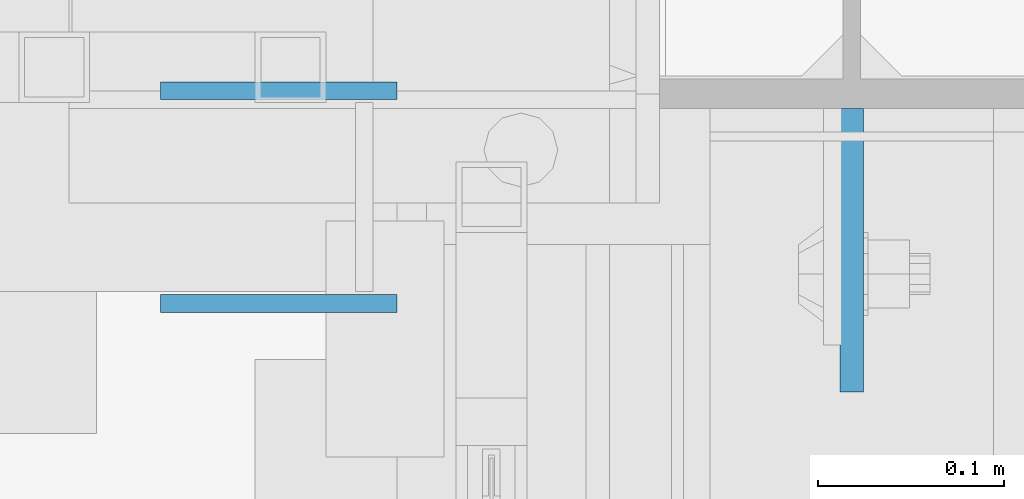
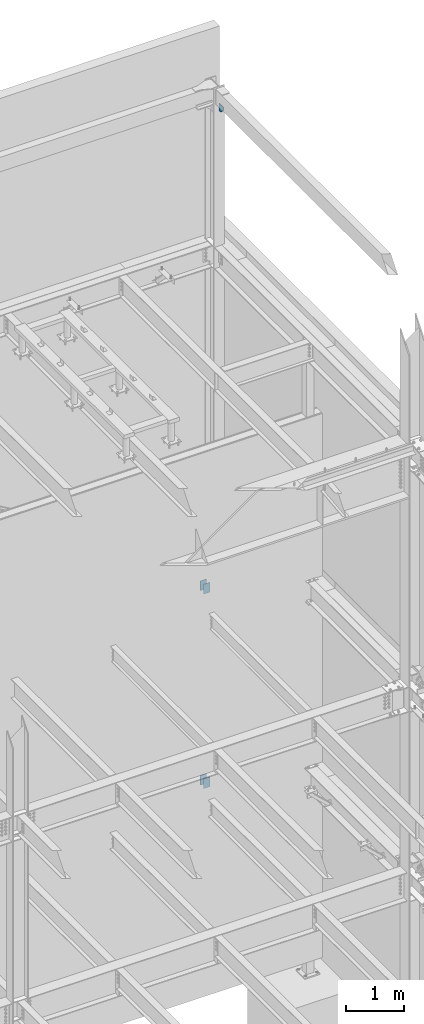
# One storey, part 1115 of 1179: 5 plates, 3 elements without a shape of their own.
"""IFC2X3 building model written with IfcOpenShell, lengths in millimetres."""

from ifc_helpers import new_model, si_unit, frame, origin_with_axes, place, context, subcontext, project, spatial, faceted_brep, material, type_object, element, aggregate, save


model = new_model("IFC2X3")

# Units and contexts
model_context = context("Model", 3, precision=1e-05, world=origin_with_axes())
body_context = subcontext(model_context, "Body", "Model", "MODEL_VIEW")
ifc_project = project(units=[si_unit("LENGTHUNIT", "METRE", prefix="MILLI"), si_unit("AREAUNIT", "SQUARE_METRE"), si_unit("VOLUMEUNIT", "CUBIC_METRE"), si_unit("MASSUNIT", "GRAM", prefix="KILO"), si_unit("TIMEUNIT", "SECOND"), si_unit("PLANEANGLEUNIT", "RADIAN"), si_unit("SOLIDANGLEUNIT", "STERADIAN"), si_unit("THERMODYNAMICTEMPERATUREUNIT", "DEGREE_CELSIUS"), si_unit("LUMINOUSINTENSITYUNIT", "LUMEN")], contexts=[model_context])

# Site, building, storey
site_placement = place(None, origin_with_axes())
site = spatial("IfcSite", under=ifc_project, at=site_placement, CompositionType="ELEMENT")
building_placement = place(site_placement, origin_with_axes())
building = spatial("IfcBuilding", under=site, at=building_placement, Name="Undefined", CompositionType="ELEMENT")
storey_placement = place(building_placement, origin_with_axes())
storey = spatial("IfcBuildingStorey", under=building, at=storey_placement, Name="Undefined", CompositionType="ELEMENT", Elevation=0.0)

# Assembly, plates
assembly_1_placement = place(storey_placement, origin_with_axes())
assembly_1 = element("IfcElementAssembly", 1, at=assembly_1_placement, inside=storey, Name="BEAM", AssemblyPlace="NOTDEFINED", PredefinedType="RIGID_FRAME")
ifc_material = material(Name="STEEL/A36")
plate_type_1 = type_object("IfcPlateType", PredefinedType="NOTDEFINED")
plate_1_placement = place(assembly_1_placement, frame((24063.325, 41052.75, 6191.25000001248), z_axis=(-1.0, 0.0, 0.0), x_axis=(0.0, 0.0, -1.0)))
plate_1 = element("IfcPlate", 2, at=plate_1_placement, type_object=plate_type_1, material=ifc_material, Name="PLATE", context=body_context, shape_type="Brep", body=[
    faceted_brep([(0.0, -4.76249999999709, 0.0), (0.0, -4.76249999999709, 127.0), (0.0, 4.76249999999709, 127.0), (0.0, 4.76249999999709, 0.0), (203.2, -4.76249999999709, 127.0), (203.2, 4.76249999999709, 127.0), (203.2, -4.76249999999709, 0.0), (203.2, 4.76249999999709, 0.0)], [[[0, 1, 2, 3]], [[1, 4, 5, 2]], [[4, 6, 7, 5]], [[6, 0, 3, 7]], [[5, 7, 3, 2]], [[6, 4, 1, 0]]]),
])
plate_2_placement = place(assembly_1_placement, frame((24063.325, 40938.45, 6191.25000001248), z_axis=(-1.0, 0.0, 0.0), x_axis=(0.0, 0.0, -1.0)))
plate_2 = element("IfcPlate", 3, at=plate_2_placement, type_object=plate_type_1, material=ifc_material, Name="PLATE", context=body_context, shape_type="Brep", body=[
    faceted_brep([(0.0, -4.76249999999709, 0.0), (0.0, -4.76249999999709, 127.0), (0.0, 4.76249999999709, 127.0), (0.0, 4.76249999999709, 0.0), (203.2, -4.76249999999709, 127.0), (203.2, 4.76249999999709, 127.0), (203.2, -4.76249999999709, 0.0), (203.2, 4.76249999999709, 0.0)], [[[0, 1, 2, 3]], [[1, 4, 5, 2]], [[4, 6, 7, 5]], [[6, 0, 3, 7]], [[5, 7, 3, 2]], [[6, 4, 1, 0]]]),
])
aggregate(assembly_1, [plate_1, plate_2])

assembly_2_placement = place(storey_placement, origin_with_axes())
assembly_2 = element("IfcElementAssembly", 4, at=assembly_2_placement, inside=storey, Name="BEAM", AssemblyPlace="NOTDEFINED", PredefinedType="RIGID_FRAME")
plate_3_placement = place(assembly_2_placement, frame((24063.3250004143, 41052.7499999994, 2105.02499999894), z_axis=(-1.0, 0.0, 0.0), x_axis=(0.0, 0.0, -1.0)))
plate_3 = element("IfcPlate", 5, at=plate_3_placement, type_object=plate_type_1, material=ifc_material, Name="PLATE", context=body_context, shape_type="Brep", body=[
    faceted_brep([(0.0, -4.76249999999709, 0.0), (0.0, -4.76249999999709, 127.0), (0.0, 4.76249999999709, 127.0), (0.0, 4.76249999999709, 0.0), (203.2, -4.76249999999709, 127.0), (203.2, 4.76249999999709, 127.0), (203.2, -4.76249999999709, 0.0), (203.2, 4.76249999999709, 0.0)], [[[0, 1, 2, 3]], [[1, 4, 5, 2]], [[4, 6, 7, 5]], [[6, 0, 3, 7]], [[5, 7, 3, 2]], [[6, 4, 1, 0]]]),
])
plate_4_placement = place(assembly_2_placement, frame((24063.3250004143, 40938.4499999994, 2105.02499999894), z_axis=(-1.0, 0.0, 0.0), x_axis=(0.0, 0.0, -1.0)))
plate_4 = element("IfcPlate", 6, at=plate_4_placement, type_object=plate_type_1, material=ifc_material, Name="PLATE", context=body_context, shape_type="Brep", body=[
    faceted_brep([(0.0, -4.76249999999709, 0.0), (0.0, -4.76249999999709, 127.0), (0.0, 4.76249999999709, 127.0), (0.0, 4.76249999999709, 0.0), (203.2, -4.76249999999709, 127.0), (203.2, 4.76249999999709, 127.0), (203.2, -4.76249999999709, 0.0), (203.2, 4.76249999999709, 0.0)], [[[0, 1, 2, 3]], [[1, 4, 5, 2]], [[4, 6, 7, 5]], [[6, 0, 3, 7]], [[5, 7, 3, 2]], [[6, 4, 1, 0]]]),
])
aggregate(assembly_2, [plate_3, plate_4])

# Assembly, plate
assembly_3_placement = place(storey_placement, origin_with_axes())
assembly_3 = element("IfcElementAssembly", 7, at=assembly_3_placement, inside=storey, Name="COLUMN", AssemblyPlace="NOTDEFINED", PredefinedType="RIGID_FRAME")
plate_type_2 = type_object("IfcPlateType", PredefinedType="NOTDEFINED")
plate_5_placement = place(assembly_3_placement, frame((24307.8, 40890.8250061035, 16109.95), z_axis=(0.0, 1.0, 0.0), x_axis=(0.0, 0.0, -1.0)))
plate_5 = element("IfcPlate", 8, at=plate_5_placement, type_object=plate_type_2, material=ifc_material, Name="PLATE", context=body_context, shape_type="Brep", body=[
    faceted_brep([(0.0, -6.34999999999854, 0.0), (0.0, -6.34999999999854, 152.400000000001), (0.0, 6.34999999999854, 152.400000000001), (0.0, 6.34999999999854, 0.0), (152.399993896484, -6.34999999999854, 152.399993896484), (152.399993896484, 6.34999999999854, 152.399993896484), (152.399993896484, -6.34999999999854, 88.6901931762695), (152.399993896484, 6.34999999999854, 88.6901931762695), (63.5, -6.34999999999854, 0.0), (63.5, 6.34999999999854, 0.0)], [[[0, 1, 2, 3]], [[1, 4, 5, 2]], [[4, 6, 7, 5]], [[6, 8, 9, 7]], [[8, 0, 3, 9]], [[5, 7, 9, 3, 2]], [[8, 6, 4, 1, 0]]]),
])
aggregate(assembly_3, [plate_5])

save(model, "model.ifc")
